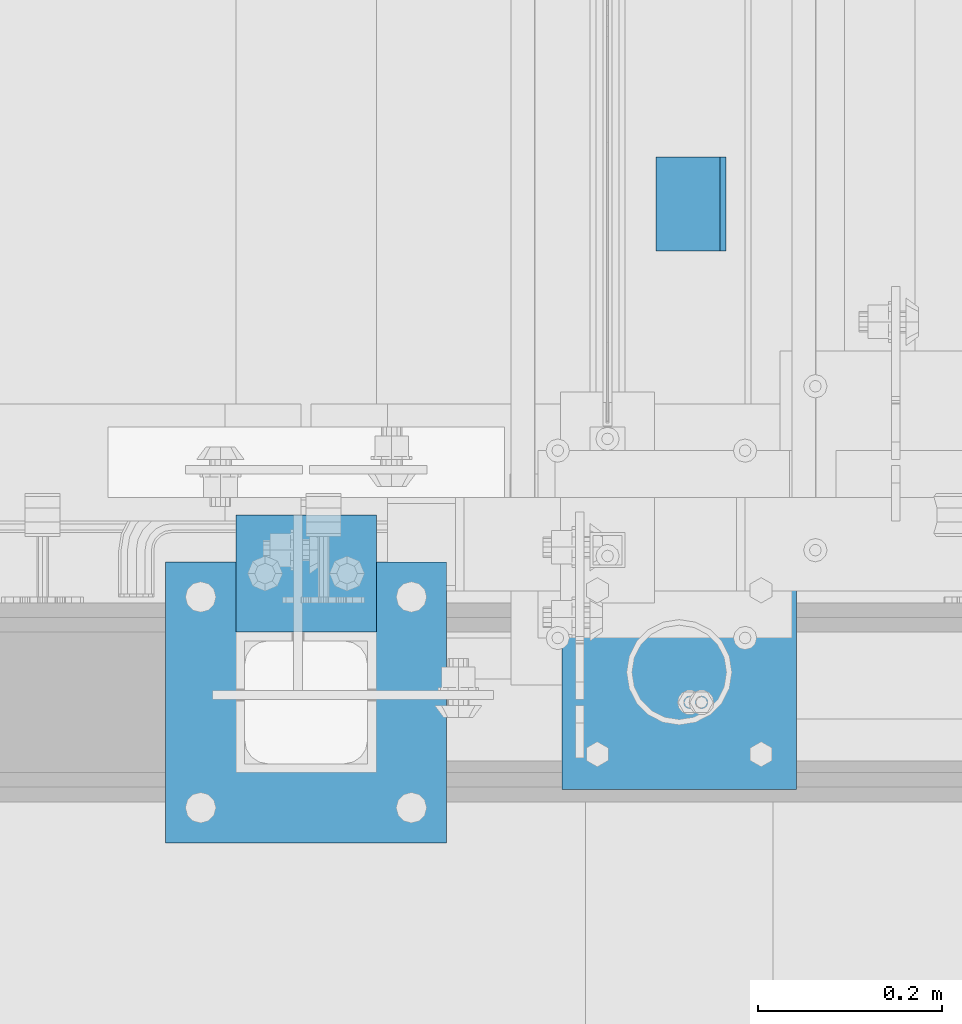
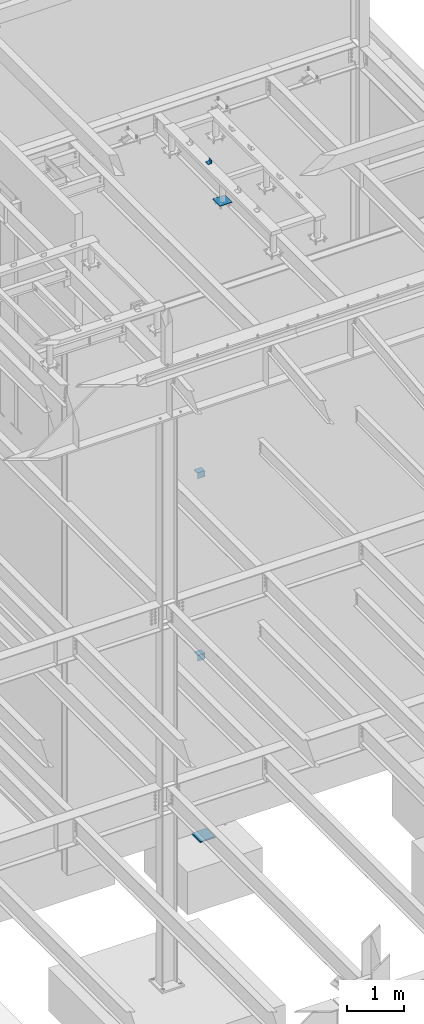
# One storey, part 904 of 1179: 5 beams, 2 elements without a shape of their own.
"""IFC2X3 building model written with IfcOpenShell, lengths in millimetres."""

from ifc_helpers import new_model, si_unit, frame, origin_with_axes, place, context, subcontext, project, spatial, faceted_brep, material, type_object, element, aggregate, save


model = new_model("IFC2X3")

# Units and contexts
model_context = context("Model", 3, precision=1e-05, world=origin_with_axes())
body_context = subcontext(model_context, "Body", "Model", "MODEL_VIEW")
ifc_project = project(units=[si_unit("LENGTHUNIT", "METRE", prefix="MILLI"), si_unit("AREAUNIT", "SQUARE_METRE"), si_unit("VOLUMEUNIT", "CUBIC_METRE"), si_unit("MASSUNIT", "GRAM", prefix="KILO"), si_unit("TIMEUNIT", "SECOND"), si_unit("PLANEANGLEUNIT", "RADIAN"), si_unit("SOLIDANGLEUNIT", "STERADIAN"), si_unit("THERMODYNAMICTEMPERATUREUNIT", "DEGREE_CELSIUS"), si_unit("LUMINOUSINTENSITYUNIT", "LUMEN")], contexts=[model_context])

# Site, building, storey
site_placement = place(None, origin_with_axes())
site = spatial("IfcSite", under=ifc_project, at=site_placement, CompositionType="ELEMENT")
building_placement = place(site_placement, origin_with_axes())
building = spatial("IfcBuilding", under=site, at=building_placement, Name="Undefined", CompositionType="ELEMENT")
storey_placement = place(building_placement, origin_with_axes())
storey = spatial("IfcBuildingStorey", under=building, at=storey_placement, Name="Undefined", CompositionType="ELEMENT", Elevation=0.0)

# Assembly, beams
assembly_1_placement = place(storey_placement, origin_with_axes())
assembly_1 = element("IfcElementAssembly", 1, at=assembly_1_placement, inside=storey, Name="FRAME", AssemblyPlace="NOTDEFINED", PredefinedType="RIGID_FRAME")
ifc_material_1 = material(Name="STEEL/A36")
beam_type_1 = type_object("IfcBeamType", Name="L3X3X1/4", PredefinedType="NOTDEFINED")
beam_1_placement = place(assembly_1_placement, frame((19696.1125, 38475.5225542222, 13798.55), z_axis=(-1.0, 0.0, 0.0), x_axis=(0.0, 1.0, 0.0)))
beam_1 = element("IfcBeam", 2, at=beam_1_placement, type_object=beam_type_1, material=ifc_material_1, Name="ANGLE", ObjectType="L3X3X1/4", context=body_context, shape_type="Brep", body=[
    faceted_brep([(0.0, 38.0999999999985, -38.0999999999999), (0.0, 38.0999999999985, 38.0999999999999), (101.600000000035, 38.0999999999985, 38.099999999994), (101.599999999962, 38.0999999999985, -38.1000000000058), (0.0, 31.75, 38.1000000000004), (101.600000000035, 31.75, 38.099999999994), (0.0, 31.75, -31.75), (101.599999999969, 31.75, -31.7500000000064), (0.0, -38.0999999999985, -31.75), (101.599999999969, -38.0999999999985, -31.7500000000064), (0.0, -38.0999999999985, -38.0999999999999), (101.599999999962, -38.0999999999985, -38.1000000000058)], [[[0, 1, 2, 3]], [[1, 4, 5, 2]], [[4, 6, 7, 5]], [[6, 8, 9, 7]], [[8, 10, 11, 9]], [[10, 0, 3, 11]], [[5, 7, 9, 11, 3, 2]], [[10, 8, 6, 4, 1, 0]]]),
])
beam_type_2 = type_object("IfcBeamType", PredefinedType="NOTDEFINED")
beam_2_placement = place(assembly_1_placement, frame((19683.4125, 37891.3225542222, 13258.8), z_axis=(1.0, 0.0, 0.0), x_axis=(0.0, 1.0, 0.0)))
beam_2 = element("IfcBeam", 3, at=beam_2_placement, type_object=beam_type_2, material=ifc_material_1, Name="PLATE", context=body_context, shape_type="Brep", body=[
    faceted_brep([(0.0, 6.35000000000036, -127.0), (0.0, 6.34999999999854, 127.0), (254.0, 6.35000000000036, 127.0), (254.0, 6.35000000000036, -127.0), (0.0, -6.34999999999854, 127.0), (254.0, -6.35000000000036, 127.0), (0.0, -6.35000000000036, -127.0), (254.0, -6.35000000000036, -127.0)], [[[0, 1, 2, 3]], [[1, 4, 5, 2]], [[4, 6, 7, 5]], [[6, 0, 3, 7]], [[5, 7, 3, 2]], [[6, 4, 1, 0]]]),
])
aggregate(assembly_1, [beam_1, beam_2])

assembly_2_placement = place(storey_placement, origin_with_axes())
assembly_2 = element("IfcElementAssembly", 4, at=assembly_2_placement, inside=storey, Name="COLUMN", AssemblyPlace="NOTDEFINED", PredefinedType="RIGID_FRAME")
beam_type_3 = type_object("IfcBeamType", Name="L5X5X3/8", PredefinedType="NOTDEFINED")
beam_3_placement = place(assembly_2_placement, frame((19202.4, 38125.4, 7496.175), z_axis=(0.0, 0.0, -1.0), x_axis=(1.0, 0.0, 0.0)))
beam_3 = element("IfcBeam", 5, at=beam_3_placement, type_object=beam_type_3, material=ifc_material_1, Name="ANGLE", ObjectType="L5X5X3/8", context=body_context, shape_type="Brep", body=[
    faceted_brep([(0.0, 63.5, -63.5), (0.0, 63.5, 63.5), (152.400000000001, 63.5, 63.5), (152.400000000001, 63.5, -63.5), (0.0, 53.9749999999985, 63.5), (152.400000000001, 53.9749999999985, 63.5), (0.0, 53.9749999999985, -53.9750000000004), (152.400000000001, 53.9749999999985, -53.9750000000004), (0.0, -63.5, -53.9750000000004), (152.400000000001, -63.5, -53.9750000000004), (0.0, -63.5, -63.5), (152.400000000001, -63.5, -63.5)], [[[0, 1, 2, 3]], [[1, 4, 5, 2]], [[4, 6, 7, 5]], [[6, 8, 9, 7]], [[8, 10, 11, 9]], [[10, 0, 3, 11]], [[5, 7, 9, 11, 3, 2]], [[10, 8, 6, 4, 1, 0]]]),
])
beam_4_placement = place(assembly_2_placement, frame((19202.4, 38125.4, 3584.575), z_axis=(0.0, 0.0, -1.0), x_axis=(1.0, 0.0, 0.0)))
beam_4 = element("IfcBeam", 6, at=beam_4_placement, type_object=beam_type_3, material=ifc_material_1, Name="ANGLE", ObjectType="L5X5X3/8", context=body_context, shape_type="Brep", body=[
    faceted_brep([(0.0, 63.5, -63.5), (0.0, 63.5, 63.5), (152.400000000001, 63.5, 63.5), (152.400000000001, 63.5, -63.5), (0.0, 53.9749999999985, 63.5), (152.400000000001, 53.9749999999985, 63.5), (0.0, 53.9749999999985, -53.9750000000004), (152.400000000001, 53.9749999999985, -53.9750000000004), (0.0, -63.5, -53.9750000000004), (152.400000000001, -63.5, -53.9750000000004), (0.0, -63.5, -63.5), (152.400000000001, -63.5, -63.5)], [[[0, 1, 2, 3]], [[1, 4, 5, 2]], [[4, 6, 7, 5]], [[6, 8, 9, 7]], [[8, 10, 11, 9]], [[10, 0, 3, 11]], [[5, 7, 9, 11, 3, 2]], [[10, 8, 6, 4, 1, 0]]]),
])
ifc_material_2 = material(Name="STEEL/A572-GR.50")
beam_type_4 = type_object("IfcBeamType", PredefinedType="NOTDEFINED")
beam_5_placement = place(assembly_2_placement, frame((19126.2, 37985.7, -190.5), z_axis=(0.0, 1.0, 0.0), x_axis=(1.0, 0.0, 0.0)))
beam_5 = element("IfcBeam", 7, at=beam_5_placement, type_object=beam_type_4, material=ifc_material_2, context=body_context, shape_type="Brep", body=[
    faceted_brep([(-7.27595761418343e-12, 12.7, -152.400000000011), (7.27595761418343e-12, 12.7, 152.400000000011), (304.800000000494, 12.7, 152.400000000071), (304.800000000479, 12.7, -152.39999999995), (7.27595761418343e-12, -12.7, 152.400000000011), (304.800000000494, -12.7, 152.400000000071), (-7.27595761418343e-12, -12.7, -152.400000000011), (304.800000000479, -12.7, -152.39999999995)], [[[0, 1, 2, 3]], [[1, 4, 5, 2]], [[4, 6, 7, 5]], [[6, 0, 3, 7]], [[5, 7, 3, 2]], [[6, 4, 1, 0]]]),
])
aggregate(assembly_2, [beam_3, beam_4, beam_5])

save(model, "model.ifc")
